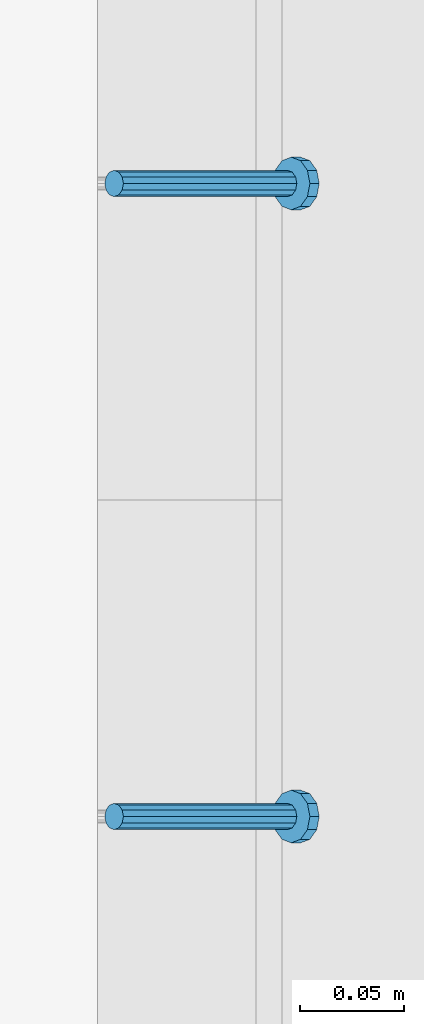
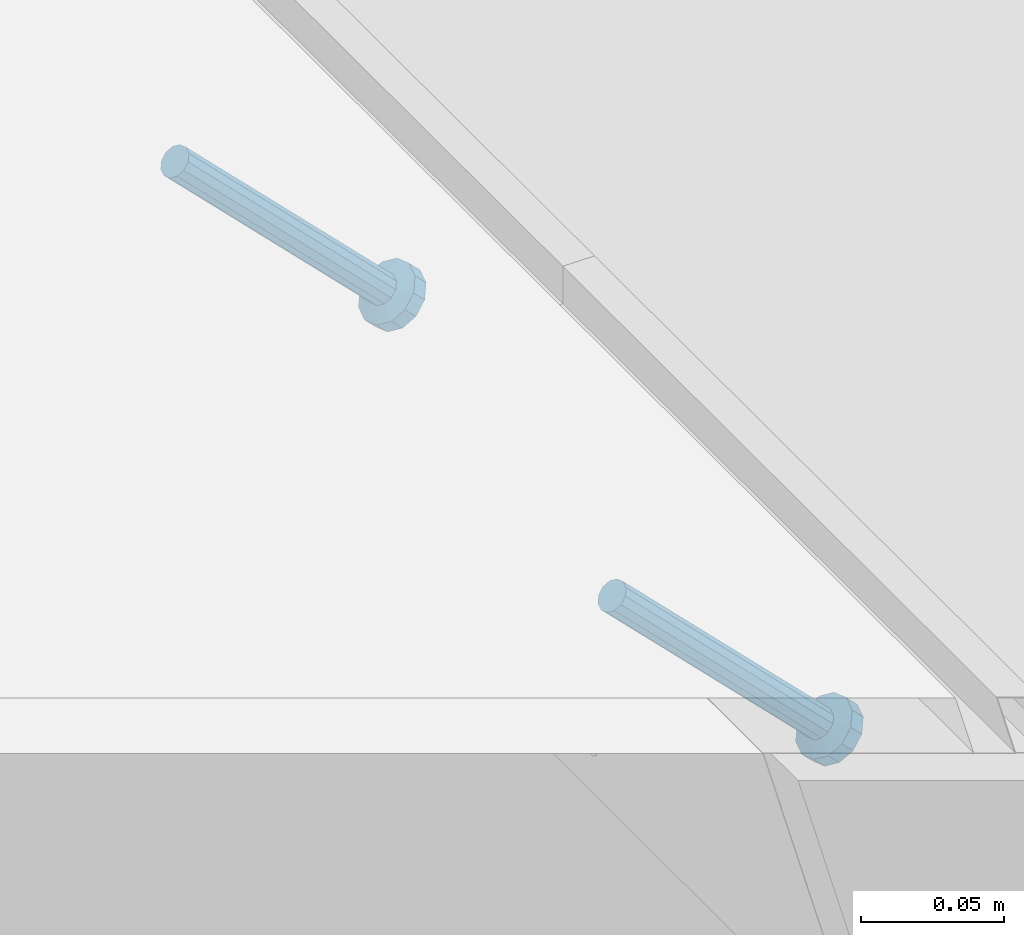
# One storey, part 2404 of 3843: 2 members, 2 elements without a shape of their own.
"""IFC2X3 building model written with IfcOpenShell, lengths in millimetres."""

from ifc_helpers import new_model, si_unit, frame, origin_with_axes, place, context, subcontext, project, spatial, faceted_brep, material, type_object, element, aggregate, save


model = new_model("IFC2X3")

# Units and contexts
model_context = context("Model", 3, precision=1e-05, world=origin_with_axes())
body_context = subcontext(model_context, "Body", "Model", "MODEL_VIEW")
ifc_project = project(units=[si_unit("LENGTHUNIT", "METRE", prefix="MILLI"), si_unit("AREAUNIT", "SQUARE_METRE"), si_unit("VOLUMEUNIT", "CUBIC_METRE"), si_unit("MASSUNIT", "GRAM", prefix="KILO"), si_unit("TIMEUNIT", "SECOND"), si_unit("PLANEANGLEUNIT", "RADIAN"), si_unit("SOLIDANGLEUNIT", "STERADIAN"), si_unit("THERMODYNAMICTEMPERATUREUNIT", "DEGREE_CELSIUS"), si_unit("LUMINOUSINTENSITYUNIT", "LUMEN")], contexts=[model_context])

# Site, building, storey
site_placement = place(None, origin_with_axes())
site = spatial("IfcSite", under=ifc_project, at=site_placement, CompositionType="ELEMENT")
building_placement = place(site_placement, origin_with_axes())
building = spatial("IfcBuilding", under=site, at=building_placement, Name="Undefined", CompositionType="ELEMENT")
storey_placement = place(building_placement, origin_with_axes())
storey = spatial("IfcBuildingStorey", under=building, at=storey_placement, Name="Undefined", CompositionType="ELEMENT", Elevation=0.0)

# Assembly, member
assembly_1_placement = place(storey_placement, origin_with_axes())
assembly_1 = element("IfcElementAssembly", 1, at=assembly_1_placement, inside=storey, Name="EMBED_ANGLE", AssemblyPlace="NOTDEFINED", PredefinedType="RIGID_FRAME")
ifc_material = material(Name="STEEL/A108")
member_type = type_object("IfcMemberType", PredefinedType="NOTDEFINED")
member_1_placement = place(assembly_1_placement, frame((44851.3834999999, 83365.975189209, 30456.1875), z_axis=(0.0, 1.0, 0.0), x_axis=(0.707106781186548, 0.0, -0.707106781186548)))
member_1 = element("IfcMember", 2, at=member_1_placement, type_object=member_type, material=ifc_material, Name="HEADED STUD ANCHOR", context=body_context, shape_type="Brep", body=[
    faceted_brep([(7.27595761418343e-12, -3.18000006675175, 5.5), (0.0, -5.49999999998363, 3.1800000667572), (118.110000000976, -5.49999999999091, 3.1800000667572), (118.110000000983, -3.18000006675175, 5.5), (0.0, -6.3499999046162, 0.0), (118.110000000968, -6.34999990461256, 0.0), (0.0, -5.49999999998363, -3.1800000667572), (118.110000000976, -5.49999999999091, -3.1800000667572), (7.27595761418343e-12, -3.18000006675175, -5.5), (118.110000000983, -3.18000006675175, -5.5), (7.27595761418343e-12, -1.81898940354586e-12, -6.34999990463257), (118.110000000968, -1.81898940354586e-12, -6.34999990463257), (0.0, 3.18000006675175, -5.5), (118.110000000968, 3.18000006674811, -5.5), (7.27595761418343e-12, 5.49999999998363, -3.1800000667572), (118.110000000983, 5.49999999998363, -3.1800000667572), (7.27595761418343e-12, 6.3499999046162, 0.0), (118.110000000976, 6.34999990461256, 0.0), (7.27595761418343e-12, 5.49999999998363, 3.1800000667572), (118.110000000983, 5.49999999998363, 3.1800000667572), (0.0, 3.18000006675175, 5.5), (118.110000000968, 3.18000006674811, 5.5), (7.27595761418343e-12, -1.81898940354586e-12, 6.34999990463257), (118.110000000968, -1.81898940354586e-12, 6.34999990463257), (120.650000000991, -10.9899997710909, 6.34999990463257), (120.650000000998, -6.34000015257152, 10.9899997711182), (120.650000000991, -12.6999998092379, 0.0), (120.650000000991, -10.9899997710909, -6.34999990463257), (120.650000000998, -6.34000015257152, -10.9899997711182), (120.650000000991, -1.81898940354586e-12, -12.6899995803833), (120.650000000991, 6.34000015257152, -10.9899997711182), (120.650000000998, 10.9899997710909, -6.34999990463257), (120.650000000991, 12.6999998092342, 0.0), (120.650000000998, 10.9899997710909, 6.34999990463257), (120.650000000991, 6.34000015257152, 10.9899997711182), (120.650000000991, -1.81898940354586e-12, 12.6899995803833), (127.000000001048, -10.9899997710945, 6.34999990463257), (127.000000001048, -6.34000015257152, 10.9899997711182), (127.000000001048, -12.6999998092342, 0.0), (127.000000001048, -10.9899997710945, -6.34999990463257), (127.000000001048, -6.34000015257152, -10.9899997711182), (127.000000001048, 1.81898940354586e-12, -12.6899995803833), (127.000000001048, 6.34000015256788, -10.9899997711182), (127.000000001048, 10.9899997710909, -6.34999990463257), (127.000000001048, 12.6999998092379, 0.0), (127.000000001048, 10.9899997710909, 6.34999990463257), (127.000000001048, 6.34000015256788, 10.9899997711182), (127.000000001048, 1.81898940354586e-12, 12.6899995803833)], [[[0, 1, 2, 3]], [[1, 4, 5, 2]], [[4, 6, 7, 5]], [[6, 8, 9, 7]], [[8, 10, 11, 9]], [[10, 12, 13, 11]], [[12, 14, 15, 13]], [[14, 16, 17, 15]], [[16, 18, 19, 17]], [[18, 20, 21, 19]], [[20, 22, 23, 21]], [[22, 0, 3, 23]], [[22, 20, 18, 16, 14, 12, 10, 8, 6, 4, 1, 0]], [[3, 2, 24, 25]], [[2, 5, 26, 24]], [[5, 7, 27, 26]], [[7, 9, 28, 27]], [[9, 11, 29, 28]], [[11, 13, 30, 29]], [[13, 15, 31, 30]], [[15, 17, 32, 31]], [[17, 19, 33, 32]], [[19, 21, 34, 33]], [[21, 23, 35, 34]], [[23, 3, 25, 35]], [[25, 24, 36, 37]], [[24, 26, 38, 36]], [[26, 27, 39, 38]], [[27, 28, 40, 39]], [[28, 29, 41, 40]], [[29, 30, 42, 41]], [[30, 31, 43, 42]], [[31, 32, 44, 43]], [[32, 33, 45, 44]], [[33, 34, 46, 45]], [[34, 35, 47, 46]], [[35, 25, 37, 47]], [[38, 39, 40, 41, 42, 43, 44, 45, 46, 47, 37, 36]]]),
])
aggregate(assembly_1, [member_1])

assembly_2_placement = place(storey_placement, origin_with_axes())
assembly_2 = element("IfcElementAssembly", 3, at=assembly_2_placement, inside=storey, Name="EMBED_ANGLE", AssemblyPlace="NOTDEFINED", PredefinedType="RIGID_FRAME")
member_2_placement = place(assembly_2_placement, frame((44851.3834999999, 83670.775189209, 30456.1875), z_axis=(0.0, 1.0, 0.0), x_axis=(0.707106781186548, 0.0, -0.707106781186548)))
member_2 = element("IfcMember", 4, at=member_2_placement, type_object=member_type, material=ifc_material, Name="HEADED STUD ANCHOR", context=body_context, shape_type="Brep", body=[
    faceted_brep([(7.27595761418343e-12, -3.18000006675175, 5.5), (0.0, -5.49999999998363, 3.1800000667572), (118.110000000976, -5.49999999999091, 3.1800000667572), (118.110000000983, -3.18000006675175, 5.5), (0.0, -6.3499999046162, 0.0), (118.110000000968, -6.34999990461256, 0.0), (0.0, -5.49999999998363, -3.1800000667572), (118.110000000976, -5.49999999999091, -3.1800000667572), (7.27595761418343e-12, -3.18000006675175, -5.5), (118.110000000983, -3.18000006675175, -5.5), (7.27595761418343e-12, -1.81898940354586e-12, -6.34999990463257), (118.110000000968, -1.81898940354586e-12, -6.34999990463257), (0.0, 3.18000006675175, -5.5), (118.110000000968, 3.18000006674811, -5.5), (7.27595761418343e-12, 5.49999999998363, -3.1800000667572), (118.110000000983, 5.49999999998363, -3.1800000667572), (7.27595761418343e-12, 6.3499999046162, 0.0), (118.110000000976, 6.34999990461256, 0.0), (7.27595761418343e-12, 5.49999999998363, 3.1800000667572), (118.110000000983, 5.49999999998363, 3.1800000667572), (0.0, 3.18000006675175, 5.5), (118.110000000968, 3.18000006674811, 5.5), (7.27595761418343e-12, -1.81898940354586e-12, 6.34999990463257), (118.110000000968, -1.81898940354586e-12, 6.34999990463257), (120.650000000991, -10.9899997710909, 6.34999990463257), (120.650000000998, -6.34000015257152, 10.9899997711182), (120.650000000991, -12.6999998092379, 0.0), (120.650000000991, -10.9899997710909, -6.34999990463257), (120.650000000998, -6.34000015257152, -10.9899997711182), (120.650000000991, -1.81898940354586e-12, -12.6899995803833), (120.650000000991, 6.34000015257152, -10.9899997711182), (120.650000000998, 10.9899997710909, -6.34999990463257), (120.650000000991, 12.6999998092342, 0.0), (120.650000000998, 10.9899997710909, 6.34999990463257), (120.650000000991, 6.34000015257152, 10.9899997711182), (120.650000000991, -1.81898940354586e-12, 12.6899995803833), (127.000000001048, -10.9899997710945, 6.34999990463257), (127.000000001048, -6.34000015257152, 10.9899997711182), (127.000000001048, -12.6999998092342, 0.0), (127.000000001048, -10.9899997710945, -6.34999990463257), (127.000000001048, -6.34000015257152, -10.9899997711182), (127.000000001048, 1.81898940354586e-12, -12.6899995803833), (127.000000001048, 6.34000015256788, -10.9899997711182), (127.000000001048, 10.9899997710909, -6.34999990463257), (127.000000001048, 12.6999998092379, 0.0), (127.000000001048, 10.9899997710909, 6.34999990463257), (127.000000001048, 6.34000015256788, 10.9899997711182), (127.000000001048, 1.81898940354586e-12, 12.6899995803833)], [[[0, 1, 2, 3]], [[1, 4, 5, 2]], [[4, 6, 7, 5]], [[6, 8, 9, 7]], [[8, 10, 11, 9]], [[10, 12, 13, 11]], [[12, 14, 15, 13]], [[14, 16, 17, 15]], [[16, 18, 19, 17]], [[18, 20, 21, 19]], [[20, 22, 23, 21]], [[22, 0, 3, 23]], [[22, 20, 18, 16, 14, 12, 10, 8, 6, 4, 1, 0]], [[3, 2, 24, 25]], [[2, 5, 26, 24]], [[5, 7, 27, 26]], [[7, 9, 28, 27]], [[9, 11, 29, 28]], [[11, 13, 30, 29]], [[13, 15, 31, 30]], [[15, 17, 32, 31]], [[17, 19, 33, 32]], [[19, 21, 34, 33]], [[21, 23, 35, 34]], [[23, 3, 25, 35]], [[25, 24, 36, 37]], [[24, 26, 38, 36]], [[26, 27, 39, 38]], [[27, 28, 40, 39]], [[28, 29, 41, 40]], [[29, 30, 42, 41]], [[30, 31, 43, 42]], [[31, 32, 44, 43]], [[32, 33, 45, 44]], [[33, 34, 46, 45]], [[34, 35, 47, 46]], [[35, 25, 37, 47]], [[38, 39, 40, 41, 42, 43, 44, 45, 46, 47, 37, 36]]]),
])
aggregate(assembly_2, [member_2])

save(model, "model.ifc")
